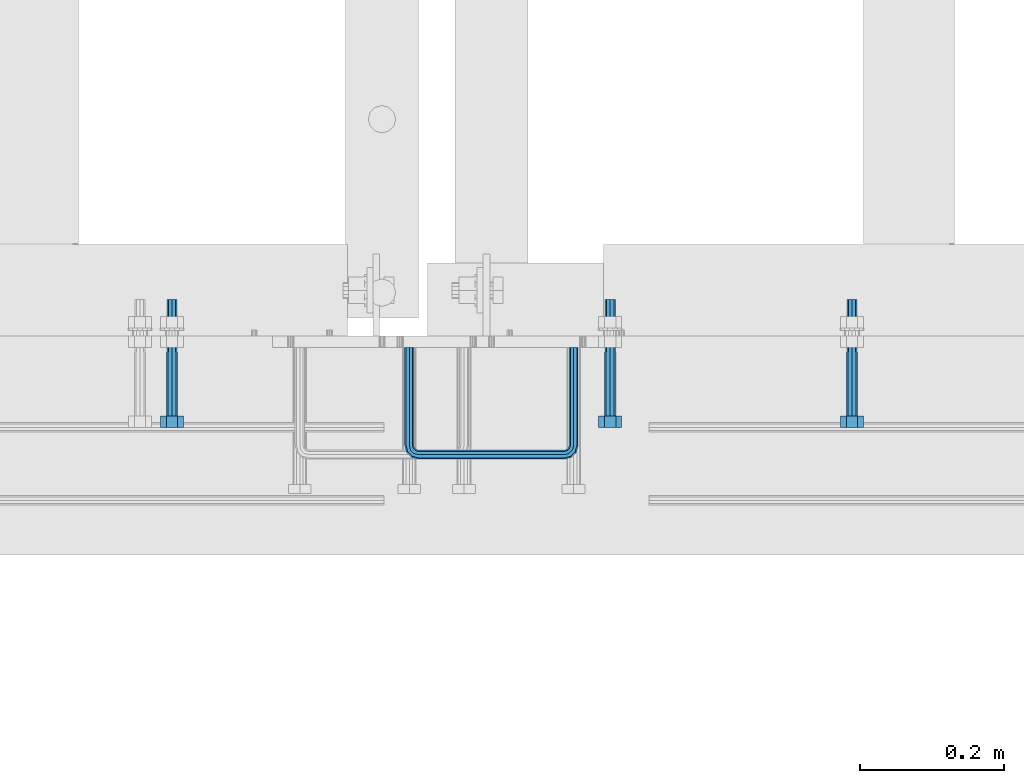
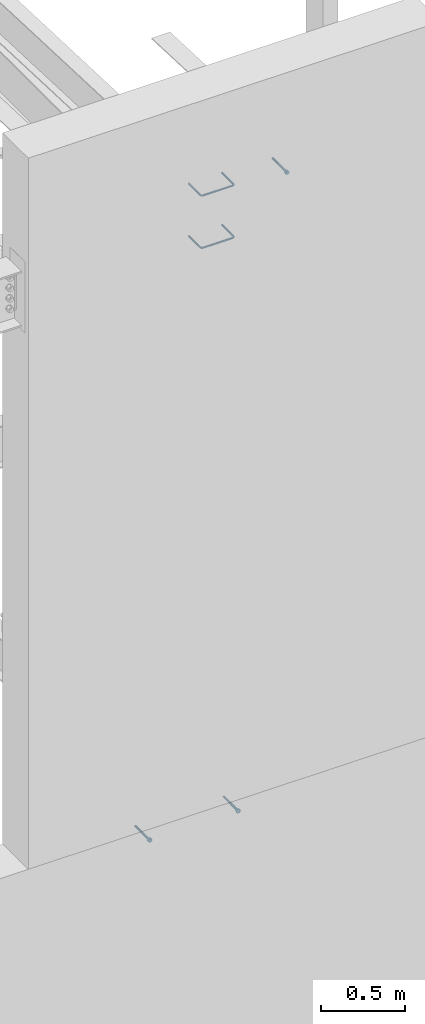
# One storey, part 408 of 975: 5 beams.
"""IFC2X3 building model written with IfcOpenShell, lengths in millimetres."""

import ifcopenshell
import ifcopenshell.guid

model = None  # the IFC model being written
_history = None  # IfcOwnerHistory: only IFC2X3 demands one
_inside = {}  # id of a spatial element -> (the spatial element, [elements in it])
_under = {}  # id of a project, library or spatial element -> (it, [spatial elements below it])
_declared = {}  # id of a project -> (the project, [libraries it declares])
_typed = {}  # id of a type object -> (the type object, [elements of that type])
_made_of = {}  # id of a material, layer set ... -> (it, [elements and type objects made of it])


def new_model(schema):
    """Start an empty IFC model of exactly this schema.

    Asked for "IFC4X3", IfcOpenShell would pick the latest addendum, in which some entities
    have other attributes; the version numbers below select the first issue.
    IFC2X3 requires an IfcOwnerHistory on every rooted entity: one is made here for all.
    """
    global model, _history
    if schema == "IFC4X3":
        model = ifcopenshell.file(schema_version=(4, 3, 0, 0))
    else:
        model = ifcopenshell.file(schema=schema)
    _inside.clear()
    _under.clear()
    _declared.clear()
    _typed.clear()
    _made_of.clear()
    _history = None
    if model.schema == "IFC2X3":
        org = make("IfcOrganization", Name="unknown")
        user = make(
            "IfcPersonAndOrganization",
            ThePerson=make("IfcPerson", FamilyName="unknown"),
            TheOrganization=org,
        )
        app = make(
            "IfcApplication",
            ApplicationDeveloper=org,
            Version="unknown",
            ApplicationFullName="unknown",
            ApplicationIdentifier="unknown",
        )
        _history = make(
            "IfcOwnerHistory",
            OwningUser=user,
            OwningApplication=app,
            ChangeAction="ADDED",
            CreationDate=0,
        )
    return model


def make(cls, **values):
    """One entity of the class cls with the attributes given. An attribute that is None is left unset."""
    return model.create_entity(
        cls, **{name: value for name, value in values.items() if value is not None}
    )


def rooted(cls, **values):
    """An entity with a GlobalId (a new one), such as an element, a storey or a relation."""
    return make(cls, GlobalId=ifcopenshell.guid.new(), OwnerHistory=_history, **values)


def si_unit(unit_type, name, prefix=None):
    """IfcSIUnit, for example si_unit("LENGTHUNIT", "METRE", prefix="MILLI")."""
    return make("IfcSIUnit", UnitType=unit_type, Prefix=prefix, Name=name)


def assignment(units):
    """IfcUnitAssignment: the units of a project."""
    return None if units is None else make("IfcUnitAssignment", Units=units)


def point(xyz):
    """IfcCartesianPoint."""
    return None if xyz is None else make("IfcCartesianPoint", Coordinates=xyz)


def direction(xyz):
    """IfcDirection."""
    return None if xyz is None else make("IfcDirection", DirectionRatios=xyz)


def frame(location, z_axis=None, x_axis=None):
    """IfcAxis2Placement3D, a coordinate frame: its origin and axes. An axis left out is left unset."""
    return make(
        "IfcAxis2Placement3D",
        Location=point(location),
        Axis=direction(z_axis),
        RefDirection=direction(x_axis),
    )


def origin_with_axes():
    """The frame at (0, 0, 0) with the z axis (0, 0, 1) and the x axis (1, 0, 0) written out."""
    return frame((0.0, 0.0, 0.0), z_axis=(0.0, 0.0, 1.0), x_axis=(1.0, 0.0, 0.0))


def place(relative_to, where):
    """IfcLocalPlacement: puts the frame where relative to a parent placement (None: the world)."""
    return make(
        "IfcLocalPlacement", PlacementRelTo=relative_to, RelativePlacement=where
    )


def context(
    kind, dimensions, precision=None, world=None, true_north=None, identifier=None
):
    """IfcGeometricRepresentationContext, for example the 3D "Model" context."""
    return make(
        "IfcGeometricRepresentationContext",
        ContextIdentifier=identifier,
        ContextType=kind,
        CoordinateSpaceDimension=dimensions,
        Precision=precision,
        WorldCoordinateSystem=world,
        TrueNorth=true_north,
    )


def subcontext(parent, identifier, kind, view, scale=None):
    """IfcGeometricRepresentationSubContext, for example "Body" below "Model"."""
    return make(
        "IfcGeometricRepresentationSubContext",
        ContextIdentifier=identifier,
        ContextType=kind,
        ParentContext=parent,
        TargetScale=scale,
        TargetView=view,
    )


def project(units=None, contexts=None):
    """IfcProject with its units and contexts."""
    return rooted(
        "IfcProject",
        Name="project",
        RepresentationContexts=contexts,
        UnitsInContext=assignment(units),
    )


def spatial(cls, under=None, at=None, **own):
    """A site, building, storey or space (cls), placed at a placement, below another one or the project."""
    s = rooted(cls, ObjectPlacement=at, **own)
    if under is not None:
        _under.setdefault(under.id(), (under, []))[1].append(s)
    return s


def faces_of(points, faces, orient=None, outer=None):
    """IfcFace entities. A face is a list of loops; a loop is a list of indices into points, from 0.

    orient and outer hold one flag for each loop. By default every Orientation is true, the
    first loop of a face is its IfcFaceOuterBound and the others are IfcFaceBound.
    """
    made = []
    for i, loops in enumerate(faces):
        bounds = []
        for j, loop in enumerate(loops):
            is_outer = j == 0 if outer is None else outer[i][j]
            bounds.append(
                make(
                    "IfcFaceOuterBound" if is_outer else "IfcFaceBound",
                    Bound=make("IfcPolyLoop", Polygon=[points[k] for k in loop]),
                    Orientation=True if orient is None else orient[i][j],
                )
            )
        made.append(make("IfcFace", Bounds=bounds))
    return made


def faceted_brep(points, faces, orient=None, outer=None, voids=None):
    """IfcFacetedBrep: a solid bounded by flat faces; with voids (closed shells), ...WithVoids."""
    shared = [point(p) for p in points]
    hull = make("IfcClosedShell", CfsFaces=faces_of(shared, faces, orient, outer))
    if voids is None:
        return make("IfcFacetedBrep", Outer=hull)
    return make(
        "IfcFacetedBrepWithVoids",
        Outer=hull,
        Voids=[
            make(cls, CfsFaces=faces_of(shared, fs, o, b)) for cls, fs, o, b in voids
        ],
    )


def shape(context_of_items, identifier, shape_type, items):
    """IfcShapeRepresentation: the items that make up one representation, for example the "Body"."""
    return make(
        "IfcShapeRepresentation",
        ContextOfItems=context_of_items,
        RepresentationIdentifier=identifier,
        RepresentationType=shape_type,
        Items=items,
    )


def material(Name=None, Category=None):
    """IfcMaterial."""
    return make("IfcMaterial", Name=Name, Category=Category)


def made_of(thing, what):
    """Note that an element or type object is made of a material, layer set ...; save() writes the relation."""
    if what is not None:
        _made_of.setdefault(what.id(), (what, []))[1].append(thing)
    return thing


def type_object(cls, material=None, **own):
    """A type object (cls), such as IfcWallType, which elements share."""
    return made_of(rooted(cls, **own), material)


def element(
    cls,
    number,
    at=None,
    inside=None,
    cuts=None,
    type_object=None,
    material=None,
    context=None,
    identifier="Body",
    shape_type=None,
    held_by="IfcProductDefinitionShape",
    body=None,
    shapes=None,
    **own,
):
    """One element of the class cls, such as IfcWall. Its Tag is "e" and its number.

    at: its placement. inside: the storey or other place that contains it. cuts: it is an
    opening in that element (IfcRelVoidsElement). A single representation is given by context,
    identifier, shape_type and body (its items); several are given by shapes. held_by: the class
    of the entity that holds the representations. save() writes the other relations.
    """
    e = rooted(cls, Tag="e%d" % number, ObjectPlacement=at, **own)
    if body is not None:
        shapes = [shape(context, identifier, shape_type, body)]
    if shapes is not None:
        e.Representation = make(held_by, Representations=shapes)
    if inside is not None:
        _inside.setdefault(inside.id(), (inside, []))[1].append(e)
    if cuts is not None:
        rooted(
            "IfcRelVoidsElement", RelatingBuildingElement=cuts, RelatedOpeningElement=e
        )
    if type_object is not None:
        _typed.setdefault(type_object.id(), (type_object, []))[1].append(e)
    return made_of(e, material)


def aggregate(whole, parts):
    """IfcRelAggregates: a whole, such as a stair, and the parts it consists of."""
    return rooted("IfcRelAggregates", RelatingObject=whole, RelatedObjects=parts)


def save(model, path):
    """Write the relations noted so far, then the file.

    IfcRelAggregates (storeys below a building ...), IfcRelContainedInSpatialStructure (elements
    in a storey), IfcRelDefinesByType, IfcRelAssociatesMaterial and IfcRelDeclares: one each for
    every whole, place, type object, material and project.
    """
    for whole, parts in _under.values():
        aggregate(whole, parts)
    for where, things in _inside.values():
        rooted(
            "IfcRelContainedInSpatialStructure",
            RelatedElements=things,
            RelatingStructure=where,
        )
    for kind, things in _typed.values():
        rooted("IfcRelDefinesByType", RelatedObjects=things, RelatingType=kind)
    for what, things in _made_of.values():
        rooted("IfcRelAssociatesMaterial", RelatedObjects=things, RelatingMaterial=what)
    for by, libraries in _declared.values():
        rooted("IfcRelDeclares", RelatingContext=by, RelatedDefinitions=libraries)
    model.write(path)


model = new_model("IFC2X3")

# Units and contexts
model_context = context("Model", 3, precision=1e-05, world=origin_with_axes())
body_context = subcontext(model_context, "Body", "Model", "MODEL_VIEW")
ifc_project = project(units=[si_unit("LENGTHUNIT", "METRE", prefix="MILLI"), si_unit("AREAUNIT", "SQUARE_METRE"), si_unit("VOLUMEUNIT", "CUBIC_METRE"), si_unit("MASSUNIT", "GRAM", prefix="KILO"), si_unit("TIMEUNIT", "SECOND"), si_unit("PLANEANGLEUNIT", "RADIAN"), si_unit("SOLIDANGLEUNIT", "STERADIAN"), si_unit("THERMODYNAMICTEMPERATUREUNIT", "DEGREE_CELSIUS"), si_unit("LUMINOUSINTENSITYUNIT", "LUMEN")], contexts=[model_context])

# Site, building, storey
site_placement = place(None, origin_with_axes())
site = spatial("IfcSite", under=ifc_project, at=site_placement, CompositionType="ELEMENT")
building_placement = place(site_placement, origin_with_axes())
building = spatial("IfcBuilding", under=site, at=building_placement, Name="Undefined", CompositionType="ELEMENT")
storey_placement = place(building_placement, origin_with_axes())
storey = spatial("IfcBuildingStorey", under=building, at=storey_placement, Name="Undefined", CompositionType="ELEMENT", Elevation=0.0)

# Beams
ifc_material_1 = material(Name="STEEL/F1554-36")
beam_type_1 = type_object("IfcBeamType", PredefinedType="NOTDEFINED")
beam_1_placement = place(storey_placement, frame((24225.2500236716, 282.575084098113, 8420.10000031656), z_axis=(0.0, 0.0, -1.0), x_axis=(0.0, -1.0, 0.0)))
element("IfcBeam", 1, at=beam_1_placement, inside=storey, type_object=beam_type_1, material=ifc_material_1, Name="HEADED_ANCHOR_BOLT", context=body_context, shape_type="Brep", body=[
    faceted_brep([(88.9000000184824, 7.94000001861696, -13.7499999799138), (88.8999999527368, 15.8800000758411, 2.00943759409711e-08), (104.774999952569, 15.8800001213949, 6.97191353538074e-08), (104.775000018315, 7.94000006417082, -13.7499999302891), (88.900000064019, -7.94000009583215, -13.7499999799147), (104.775000063852, -7.9400000502792, -13.74999993029), (88.9000000438027, -15.880000153059, 2.00925569515675e-08), (104.775000043643, -15.8800001075042, 6.9716406869702e-08), (88.8999999780608, -7.94000009583488, 13.7500000200998), (104.774999977893, -7.94000005028101, 13.7500000697237), (88.8999999325279, 7.94000001861514, 13.7500000201007), (104.774999932361, 7.940000064169, 13.7500000697246), (88.9000000119959, 3.78780480527439, -7.86545778426807), (88.8999999957159, 6.82538844544797, -5.4430656647246), (88.8999999799416, 8.51112018845743, -1.94260763148395), (88.8999999677944, 8.51112018845652, 1.94260767167179), (88.8999999616899, 6.82538844544615, 5.44306570491244), (88.8999999628249, 3.78780480527257, 7.86545782445592), (88.8999999709849, -3.86089595849626e-08, 8.72999956233434), (88.8999999845473, -3.7878048824914, 7.8654578244541), (88.9000000008309, -6.82538852266407, 5.44306570491153), (88.9000000166052, -8.51112026567444, 1.94260767166998), (88.9000000287488, -8.51112026567353, -1.94260763148577), (88.9000000348606, -6.82538852266407, -5.44306566472642), (88.9000000337182, -3.78780488248958, -7.86545778426898), (88.9000000255583, -3.86080500902608e-08, -8.72999952214832), (104.775000025395, 6.94581103743985e-09, -8.72999947252447), (104.775000011829, 3.78780485082825, -7.86545773464422), (104.774999995549, 6.82538849100092, -5.44306561510075), (104.774999979774, 8.51112023401038, -1.9426075818601), (104.774999967627, 8.51112023401038, 1.94260772129564), (104.774999961523, 6.82538849100092, 5.44306575453629), (104.774999962658, 3.78780485082643, 7.86545787407977), (104.774999970818, 6.94399204803631e-09, 8.7299996119591), (104.77499998438, -3.78780483693754, 7.86545787407886), (104.775000000664, -6.82538847711112, 5.44306575453538), (104.775000016438, -8.51112022012057, 1.94260772129473), (104.775000028581, -8.51112022012057, -1.94260758186101), (104.775000034693, -6.82538847711021, -5.44306561510166), (104.775000033551, -3.78780483693663, -7.86545773464422), (-2.99107341561466e-07, -5.61266007567065, 5.61266007566792), (-4.22995071858168e-07, -7.93750000000728, 0.0), (104.774999998088, -7.93749999999, -4.45652403868735e-11), (104.774999998088, -5.61266007565791, 5.61266007562426), (-1.09139364212751e-11, 1.81898940354586e-12, 7.9375), (104.774999998095, 1.18234311230481e-11, 7.93749999995816), (2.99089151667431e-07, 5.61266007567428, 5.61266007566792), (104.774999998102, 5.61266007568065, 5.61266007562517), (4.22980519942939e-07, 7.93750000001091, 0.0), (104.77499999811, 7.93750000001364, -4.36557456851006e-11), (2.99089151667431e-07, 5.61266007567428, -5.61266007566792), (104.774999998102, 5.61266007568156, -5.61266007571339), (-1.09139364212751e-11, 1.81898940354586e-12, -7.9375), (104.774999998099, 1.2732925824821e-11, -7.93750000004547), (-73.0249999592124, 5.05157065939329, -5.0515715445581), (-73.0249999269472, -1.85405951924622e-07, -7.14400069976364), (-73.0249999328516, -5.0515710302052, -5.05157154455992), (-73.0249999734697, -7.14400018541073, -6.9975976657588e-07), (-73.0250000250016, -5.05157103020611, 5.05157014504039), (-73.0250000572705, -1.85406861419324e-07, 7.1439993002441), (-73.0250000513661, 5.05157065939238, 5.05157014503948), (-73.025000010748, 7.14399981459792, -6.99758857081179e-07), (0.00625003290042514, 5.05157085007795, -5.05157087849238), (0.00625006516929716, 5.27870724909008e-09, -7.1440000336961), (0.00625005926485755, -5.05157083952145, -5.05157087849329), (0.00625001864682417, -7.14399999472516, -3.36940502165817e-08), (0.00624996711121639, -5.05157083952145, 5.05157081110519), (0.00624993484598235, 5.2777977543883e-09, 7.14399996631164), (0.00624994074678398, 5.05157085007704, 5.05157081110701), (0.00624998136845534, 7.14400000528167, -3.36922312271781e-08), (-2.99107341561466e-07, -5.61266007567065, -5.61266007566792), (104.774999998092, -5.612660075657, -5.6126600757143)], [[[0, 1, 2, 3]], [[4, 0, 3, 5]], [[6, 4, 5, 7]], [[8, 6, 7, 9]], [[10, 8, 9, 11]], [[0, 4, 6, 8, 10, 1], [12, 13, 14, 15, 16, 17, 18, 19, 20, 21, 22, 23, 24, 25]], [[12, 25, 26, 27]], [[13, 12, 27, 28]], [[14, 13, 28, 29]], [[15, 14, 29, 30]], [[16, 15, 30, 31]], [[17, 16, 31, 32]], [[18, 17, 32, 33]], [[19, 18, 33, 34]], [[20, 19, 34, 35]], [[21, 20, 35, 36]], [[22, 21, 36, 37]], [[23, 22, 37, 38]], [[24, 23, 38, 39]], [[25, 24, 39, 26]], [[9, 7, 5, 3, 2, 11], [38, 37, 36, 35, 34, 33, 32, 31, 30, 29, 28, 27, 26, 39]], [[1, 10, 11, 2]], [[40, 41, 42, 43]], [[44, 40, 43, 45]], [[46, 44, 45, 47]], [[48, 46, 47, 49]], [[50, 48, 49, 51]], [[52, 50, 51, 53]], [[54, 55, 56, 57, 58, 59, 60, 61]], [[55, 54, 62, 63]], [[56, 55, 63, 64]], [[57, 56, 64, 65]], [[58, 57, 65, 66]], [[59, 58, 66, 67]], [[60, 59, 67, 68]], [[61, 60, 68, 69]], [[54, 61, 69, 62]], [[40, 44, 46, 48, 50, 52, 70, 41], [68, 67, 66, 65, 64, 63, 62, 69]], [[41, 70, 71, 42]], [[53, 51, 49, 47, 45, 43, 42, 71]], [[70, 52, 53, 71]]]),
])
beam_2_placement = place(storey_placement, frame((23279.1, 282.575000000001, 3886.2), z_axis=(0.0, 0.0, 1.0), x_axis=(0.0, -1.0, 0.0)))
element("IfcBeam", 2, at=beam_2_placement, inside=storey, type_object=beam_type_1, material=ifc_material_1, Name="HEADED_ANCHOR_BOLT", context=body_context, shape_type="Brep", body=[
    faceted_brep([(88.9000000184824, 7.94000001861696, -13.7499999799138), (88.8999999527368, 15.8800000758411, 2.00943759409711e-08), (104.774999952569, 15.8800001213949, 6.97191353538074e-08), (104.775000018315, 7.94000006417082, -13.7499999302891), (88.900000064019, -7.94000009583215, -13.7499999799147), (104.775000063852, -7.9400000502792, -13.74999993029), (88.9000000438027, -15.880000153059, 2.00925569515675e-08), (104.775000043643, -15.8800001075042, 6.9716406869702e-08), (88.8999999780608, -7.94000009583488, 13.7500000200998), (104.774999977893, -7.94000005028101, 13.7500000697237), (88.8999999325279, 7.94000001861514, 13.7500000201007), (104.774999932361, 7.940000064169, 13.7500000697246), (88.9000000119959, 3.78780480527439, -7.86545778426807), (88.8999999957159, 6.82538844544797, -5.4430656647246), (88.8999999799416, 8.51112018845743, -1.94260763148395), (88.8999999677944, 8.51112018845652, 1.94260767167179), (88.8999999616899, 6.82538844544615, 5.44306570491244), (88.8999999628249, 3.78780480527257, 7.86545782445592), (88.8999999709849, -3.86089595849626e-08, 8.72999956233434), (88.8999999845473, -3.7878048824914, 7.8654578244541), (88.9000000008309, -6.82538852266407, 5.44306570491153), (88.9000000166052, -8.51112026567444, 1.94260767166998), (88.9000000287488, -8.51112026567353, -1.94260763148577), (88.9000000348606, -6.82538852266407, -5.44306566472642), (88.9000000337182, -3.78780488248958, -7.86545778426898), (88.9000000255583, -3.86080500902608e-08, -8.72999952214832), (104.775000025395, 6.94581103743985e-09, -8.72999947252447), (104.775000011829, 3.78780485082825, -7.86545773464422), (104.774999995549, 6.82538849100092, -5.44306561510075), (104.774999979774, 8.51112023401038, -1.9426075818601), (104.774999967627, 8.51112023401038, 1.94260772129564), (104.774999961523, 6.82538849100092, 5.44306575453629), (104.774999962658, 3.78780485082643, 7.86545787407977), (104.774999970818, 6.94399204803631e-09, 8.7299996119591), (104.77499998438, -3.78780483693754, 7.86545787407886), (104.775000000664, -6.82538847711112, 5.44306575453538), (104.775000016438, -8.51112022012057, 1.94260772129473), (104.775000028581, -8.51112022012057, -1.94260758186101), (104.775000034693, -6.82538847711021, -5.44306561510166), (104.775000033551, -3.78780483693663, -7.86545773464422), (-2.99107341561466e-07, -5.61266007567065, 5.61266007566792), (-4.22995071858168e-07, -7.93750000000728, 0.0), (104.774999998088, -7.93749999999, -4.45652403868735e-11), (104.774999998088, -5.61266007565791, 5.61266007562426), (-1.09139364212751e-11, 1.81898940354586e-12, 7.9375), (104.774999998095, 1.18234311230481e-11, 7.93749999995816), (2.99089151667431e-07, 5.61266007567428, 5.61266007566792), (104.774999998102, 5.61266007568065, 5.61266007562517), (4.22980519942939e-07, 7.93750000001091, 0.0), (104.77499999811, 7.93750000001364, -4.36557456851006e-11), (2.99089151667431e-07, 5.61266007567428, -5.61266007566792), (104.774999998102, 5.61266007568156, -5.61266007571339), (-1.09139364212751e-11, 1.81898940354586e-12, -7.9375), (104.774999998099, 1.2732925824821e-11, -7.93750000004547), (-73.0249999592124, 5.05157065939329, -5.0515715445581), (-73.0249999269472, -1.85405951924622e-07, -7.14400069976364), (-73.0249999328516, -5.0515710302052, -5.05157154455992), (-73.0249999734697, -7.14400018541073, -6.9975976657588e-07), (-73.0250000250016, -5.05157103020611, 5.05157014504039), (-73.0250000572705, -1.85406861419324e-07, 7.1439993002441), (-73.0250000513661, 5.05157065939238, 5.05157014503948), (-73.025000010748, 7.14399981459792, -6.99758857081179e-07), (0.00625003290042514, 5.05157085007795, -5.05157087849238), (0.00625006516929716, 5.27870724909008e-09, -7.1440000336961), (0.00625005926485755, -5.05157083952145, -5.05157087849329), (0.00625001864682417, -7.14399999472516, -3.36940502165817e-08), (0.00624996711121639, -5.05157083952145, 5.05157081110519), (0.00624993484598235, 5.2777977543883e-09, 7.14399996631164), (0.00624994074678398, 5.05157085007704, 5.05157081110701), (0.00624998136845534, 7.14400000528167, -3.36922312271781e-08), (-2.99107341561466e-07, -5.61266007567065, -5.61266007566792), (104.774999998092, -5.612660075657, -5.6126600757143)], [[[0, 1, 2, 3]], [[4, 0, 3, 5]], [[6, 4, 5, 7]], [[8, 6, 7, 9]], [[10, 8, 9, 11]], [[0, 4, 6, 8, 10, 1], [12, 13, 14, 15, 16, 17, 18, 19, 20, 21, 22, 23, 24, 25]], [[12, 25, 26, 27]], [[13, 12, 27, 28]], [[14, 13, 28, 29]], [[15, 14, 29, 30]], [[16, 15, 30, 31]], [[17, 16, 31, 32]], [[18, 17, 32, 33]], [[19, 18, 33, 34]], [[20, 19, 34, 35]], [[21, 20, 35, 36]], [[22, 21, 36, 37]], [[23, 22, 37, 38]], [[24, 23, 38, 39]], [[25, 24, 39, 26]], [[9, 7, 5, 3, 2, 11], [38, 37, 36, 35, 34, 33, 32, 31, 30, 29, 28, 27, 26, 39]], [[1, 10, 11, 2]], [[40, 41, 42, 43]], [[44, 40, 43, 45]], [[46, 44, 45, 47]], [[48, 46, 47, 49]], [[50, 48, 49, 51]], [[52, 50, 51, 53]], [[54, 55, 56, 57, 58, 59, 60, 61]], [[55, 54, 62, 63]], [[56, 55, 63, 64]], [[57, 56, 64, 65]], [[58, 57, 65, 66]], [[59, 58, 66, 67]], [[60, 59, 67, 68]], [[61, 60, 68, 69]], [[54, 61, 69, 62]], [[40, 44, 46, 48, 50, 52, 70, 41], [68, 67, 66, 65, 64, 63, 62, 69]], [[41, 70, 71, 42]], [[53, 51, 49, 47, 45, 43, 42, 71]], [[70, 52, 53, 71]]]),
])
beam_3_placement = place(storey_placement, frame((23888.7, 282.575000000001, 3886.2), z_axis=(0.0, 0.0, -1.0), x_axis=(0.0, -1.0, 0.0)))
element("IfcBeam", 3, at=beam_3_placement, inside=storey, type_object=beam_type_1, material=ifc_material_1, Name="HEADED_ANCHOR_BOLT", context=body_context, shape_type="Brep", body=[
    faceted_brep([(88.9000000184824, 7.94000001861696, -13.7499999799138), (88.8999999527368, 15.8800000758411, 2.00943759409711e-08), (104.774999952569, 15.8800001213949, 6.97191353538074e-08), (104.775000018315, 7.94000006417082, -13.7499999302891), (88.900000064019, -7.94000009583215, -13.7499999799147), (104.775000063852, -7.9400000502792, -13.74999993029), (88.9000000438027, -15.880000153059, 2.00925569515675e-08), (104.775000043643, -15.8800001075042, 6.9716406869702e-08), (88.8999999780608, -7.94000009583488, 13.7500000200998), (104.774999977893, -7.94000005028101, 13.7500000697237), (88.8999999325279, 7.94000001861514, 13.7500000201007), (104.774999932361, 7.940000064169, 13.7500000697246), (88.9000000119959, 3.78780480527439, -7.86545778426807), (88.8999999957159, 6.82538844544797, -5.4430656647246), (88.8999999799416, 8.51112018845743, -1.94260763148395), (88.8999999677944, 8.51112018845652, 1.94260767167179), (88.8999999616899, 6.82538844544615, 5.44306570491244), (88.8999999628249, 3.78780480527257, 7.86545782445592), (88.8999999709849, -3.86089595849626e-08, 8.72999956233434), (88.8999999845473, -3.7878048824914, 7.8654578244541), (88.9000000008309, -6.82538852266407, 5.44306570491153), (88.9000000166052, -8.51112026567444, 1.94260767166998), (88.9000000287488, -8.51112026567353, -1.94260763148577), (88.9000000348606, -6.82538852266407, -5.44306566472642), (88.9000000337182, -3.78780488248958, -7.86545778426898), (88.9000000255583, -3.86080500902608e-08, -8.72999952214832), (104.775000025395, 6.94581103743985e-09, -8.72999947252447), (104.775000011829, 3.78780485082825, -7.86545773464422), (104.774999995549, 6.82538849100092, -5.44306561510075), (104.774999979774, 8.51112023401038, -1.9426075818601), (104.774999967627, 8.51112023401038, 1.94260772129564), (104.774999961523, 6.82538849100092, 5.44306575453629), (104.774999962658, 3.78780485082643, 7.86545787407977), (104.774999970818, 6.94399204803631e-09, 8.7299996119591), (104.77499998438, -3.78780483693754, 7.86545787407886), (104.775000000664, -6.82538847711112, 5.44306575453538), (104.775000016438, -8.51112022012057, 1.94260772129473), (104.775000028581, -8.51112022012057, -1.94260758186101), (104.775000034693, -6.82538847711021, -5.44306561510166), (104.775000033551, -3.78780483693663, -7.86545773464422), (-2.99107341561466e-07, -5.61266007567065, 5.61266007566792), (-4.22995071858168e-07, -7.93750000000728, 0.0), (104.774999998088, -7.93749999999, -4.45652403868735e-11), (104.774999998088, -5.61266007565791, 5.61266007562426), (-1.09139364212751e-11, 1.81898940354586e-12, 7.9375), (104.774999998095, 1.18234311230481e-11, 7.93749999995816), (2.99089151667431e-07, 5.61266007567428, 5.61266007566792), (104.774999998102, 5.61266007568065, 5.61266007562517), (4.22980519942939e-07, 7.93750000001091, 0.0), (104.77499999811, 7.93750000001364, -4.36557456851006e-11), (2.99089151667431e-07, 5.61266007567428, -5.61266007566792), (104.774999998102, 5.61266007568156, -5.61266007571339), (-1.09139364212751e-11, 1.81898940354586e-12, -7.9375), (104.774999998099, 1.2732925824821e-11, -7.93750000004547), (-73.0249999592124, 5.05157065939329, -5.0515715445581), (-73.0249999269472, -1.85405951924622e-07, -7.14400069976364), (-73.0249999328516, -5.0515710302052, -5.05157154455992), (-73.0249999734697, -7.14400018541073, -6.9975976657588e-07), (-73.0250000250016, -5.05157103020611, 5.05157014504039), (-73.0250000572705, -1.85406861419324e-07, 7.1439993002441), (-73.0250000513661, 5.05157065939238, 5.05157014503948), (-73.025000010748, 7.14399981459792, -6.99758857081179e-07), (0.00625003290042514, 5.05157085007795, -5.05157087849238), (0.00625006516929716, 5.27870724909008e-09, -7.1440000336961), (0.00625005926485755, -5.05157083952145, -5.05157087849329), (0.00625001864682417, -7.14399999472516, -3.36940502165817e-08), (0.00624996711121639, -5.05157083952145, 5.05157081110519), (0.00624993484598235, 5.2777977543883e-09, 7.14399996631164), (0.00624994074678398, 5.05157085007704, 5.05157081110701), (0.00624998136845534, 7.14400000528167, -3.36922312271781e-08), (-2.99107341561466e-07, -5.61266007567065, -5.61266007566792), (104.774999998092, -5.612660075657, -5.6126600757143)], [[[0, 1, 2, 3]], [[4, 0, 3, 5]], [[6, 4, 5, 7]], [[8, 6, 7, 9]], [[10, 8, 9, 11]], [[0, 4, 6, 8, 10, 1], [12, 13, 14, 15, 16, 17, 18, 19, 20, 21, 22, 23, 24, 25]], [[12, 25, 26, 27]], [[13, 12, 27, 28]], [[14, 13, 28, 29]], [[15, 14, 29, 30]], [[16, 15, 30, 31]], [[17, 16, 31, 32]], [[18, 17, 32, 33]], [[19, 18, 33, 34]], [[20, 19, 34, 35]], [[21, 20, 35, 36]], [[22, 21, 36, 37]], [[23, 22, 37, 38]], [[24, 23, 38, 39]], [[25, 24, 39, 26]], [[9, 7, 5, 3, 2, 11], [38, 37, 36, 35, 34, 33, 32, 31, 30, 29, 28, 27, 26, 39]], [[1, 10, 11, 2]], [[40, 41, 42, 43]], [[44, 40, 43, 45]], [[46, 44, 45, 47]], [[48, 46, 47, 49]], [[50, 48, 49, 51]], [[52, 50, 51, 53]], [[54, 55, 56, 57, 58, 59, 60, 61]], [[55, 54, 62, 63]], [[56, 55, 63, 64]], [[57, 56, 64, 65]], [[58, 57, 65, 66]], [[59, 58, 66, 67]], [[60, 59, 67, 68]], [[61, 60, 68, 69]], [[54, 61, 69, 62]], [[40, 44, 46, 48, 50, 52, 70, 41], [68, 67, 66, 65, 64, 63, 62, 69]], [[41, 70, 71, 42]], [[53, 51, 49, 47, 45, 43, 42, 71]], [[70, 52, 53, 71]]]),
])
ifc_material_2 = material(Name="STEEL/A706")
beam_type_2 = type_object("IfcBeamType", Name="#4 TIE", PredefinedType="NOTDEFINED")
beam_4_placement = place(storey_placement, frame((23837.899991351, 288.925010501542, 8109.74772216187), z_axis=(-0.999999999999998, 6.90000001668524e-08, 0.0), x_axis=(0.0, -1.0, 0.0)))
element("IfcBeam", 4, at=beam_4_placement, inside=storey, type_object=beam_type_2, material=ifc_material_2, Name="TIE ROD", ObjectType="#4 TIE", context=body_context, shape_type="Brep", body=[
    faceted_brep([(0.0, -6.34999999998763, -3.63797880709171e-12), (0.0, -4.49012806052269, -4.49012806054634), (136.525006144455, -4.49012806053452, -4.49012811661669), (136.525006146271, -6.35000000000036, -5.60821717954241e-08), (0.0, 7.27595761418343e-12, -6.35000000000764), (136.525006143703, 0.0, -6.35000005608254), (0.0, 4.49012806053724, -4.49012806053906), (136.525006144455, 4.49012806053452, -4.49012811661669), (0.0, 6.34999999999491, 5.45696821063757e-12), (136.525006146271, 6.35000000000036, -5.60821717954241e-08), (0.0, 4.49012806052633, 4.49012806054634), (136.525006148087, 4.49012806053452, 4.49012800445234), (0.0, 0.0, 6.35000000000764), (136.525006148839, 0.0, 6.34999994391819), (0.0, -4.49012806053361, 4.49012806053543), (136.525006148087, -4.49012806053452, 4.49012800445234), (146.050006113442, 0.0, -3.79778399058796), (145.120070138105, -4.49012806053452, -2.1870876464609), (142.875006094308, -6.35000000000036, 1.70147731239558), (140.62994205051, -4.49012806053452, 5.59004227125297), (139.700006075173, 0.0, 7.20073861538003), (140.62994205051, 4.49012806053452, 5.59004227125297), (142.875006094308, 6.35000000000036, 1.70147731239558), (145.120070138105, 4.49012806053452, -2.1870876464609), (151.412093644245, 4.49012806053452, 4.10493592790226), (153.022789998455, 0.0, 3.1749999700296), (147.523528661045, 6.35000000000036, 6.34999992953635), (143.634963677846, 4.49012806053452, 8.59506393117135), (142.024267323636, 0.0, 9.5249998890431), (143.634963677846, -4.49012806053452, 8.59506393117135), (147.523528661045, -6.35000000000036, 6.34999992953635), (151.412093644245, -4.49012806053452, 4.10493592790226), (153.715134021207, 4.49012806053452, 12.6999999465306), (155.575005960673, 0.0, 12.6999999674508), (149.225005960672, 6.35000000000036, 12.6999998960273), (144.734877900137, 4.49012806053452, 12.699999845524), (142.875005960672, 0.0, 12.6999998246056), (144.734877900137, -4.49012806053452, 12.699999845524), (149.225005960671, -6.35000000000036, 12.6999998960273), (153.715134021207, -4.49012806053452, 12.6999999465306), (153.71513173569, -4.49012806053452, 215.900003176369), (149.225003675155, -6.35000000000036, 215.900003125867), (155.575003675155, 0.0, 215.900003197289), (153.71513173569, 4.49012806053452, 215.900003176369), (149.225003675155, 6.35000000000036, 215.900003125867), (144.734875614621, 4.49012806053452, 215.900003075363), (142.875003675155, 0.0, 215.900003054444), (144.734875614621, -4.49012806053452, 215.900003075363), (153.022787648382, 0.0, 225.425002877988), (151.412091300475, -4.49012806053452, 224.495066909199), (147.523526332491, -6.35000000000036, 222.25000288121), (143.634961364508, -4.49012806053452, 220.004938853222), (142.024265016601, 0.0, 219.075002884432), (143.634961364508, 4.49012806053452, 220.004938853222), (147.523526332491, 6.35000000000036, 222.25000288121), (151.412091300475, 4.49012806053452, 224.495066909199), (145.120067985683, 4.49012806053452, 230.787090305822), (146.05000397542, 0.0, 232.397786641635), (142.875003907121, 6.35000000000036, 226.898525367037), (140.629939828559, 4.49012806053452, 223.00996042825), (139.700003838822, 0.0, 221.399264092438), (140.629939828559, -4.49012806053452, 223.00996042825), (142.875003907121, -6.35000000000036, 226.898525367037), (145.120067985683, -4.49012806053452, 230.787090305822), (136.525004282814, 4.49012806053452, 233.090130852819), (136.525004327922, 0.0, 234.950002792285), (136.525004173912, 6.35000000000036, 228.600002792285), (136.52500406501, 4.49012806053452, 224.10987473175), (136.525004019901, 0.0, 222.250002792285), (136.52500406501, -4.49012806053452, 224.10987473175), (136.525004173912, -6.35000000000036, 228.600002792286), (136.525004282814, -4.49012806053452, 233.090130852819), (3.32236731992452e-06, -4.49012806053452, 233.090134164055), (3.21346533382894e-06, -6.35000000000036, 228.60000610352), (3.36747552864836e-06, 0.0, 234.95000610352), (3.32236731992452e-06, 4.49012806053452, 233.090134164055), (3.21346533382894e-06, 6.35000000000036, 228.60000610352), (3.104562892986e-06, 4.49012806053452, 224.109878042986), (3.05945422951481e-06, 0.0, 222.25000610352), (3.104562892986e-06, -4.49012806053452, 224.109878042986)], [[[0, 1, 2, 3]], [[1, 4, 5, 2]], [[4, 6, 7, 5]], [[6, 8, 9, 7]], [[8, 10, 11, 9]], [[10, 12, 13, 11]], [[12, 14, 15, 13]], [[14, 0, 3, 15]], [[14, 12, 10, 8, 6, 4, 1, 0]], [[2, 5, 16, 17]], [[3, 2, 17, 18]], [[15, 3, 18, 19]], [[13, 15, 19, 20]], [[11, 13, 20, 21]], [[9, 11, 21, 22]], [[7, 9, 22, 23]], [[5, 7, 23, 16]], [[23, 24, 25, 16]], [[22, 26, 24, 23]], [[21, 27, 26, 22]], [[20, 28, 27, 21]], [[19, 29, 28, 20]], [[18, 30, 29, 19]], [[17, 31, 30, 18]], [[16, 25, 31, 17]], [[24, 32, 33, 25]], [[26, 34, 32, 24]], [[27, 35, 34, 26]], [[28, 36, 35, 27]], [[29, 37, 36, 28]], [[30, 38, 37, 29]], [[31, 39, 38, 30]], [[25, 33, 39, 31]], [[38, 39, 40, 41]], [[39, 33, 42, 40]], [[33, 32, 43, 42]], [[32, 34, 44, 43]], [[34, 35, 45, 44]], [[35, 36, 46, 45]], [[36, 37, 47, 46]], [[37, 38, 41, 47]], [[40, 42, 48, 49]], [[41, 40, 49, 50]], [[47, 41, 50, 51]], [[46, 47, 51, 52]], [[45, 46, 52, 53]], [[44, 45, 53, 54]], [[43, 44, 54, 55]], [[42, 43, 55, 48]], [[55, 56, 57, 48]], [[54, 58, 56, 55]], [[53, 59, 58, 54]], [[52, 60, 59, 53]], [[51, 61, 60, 52]], [[50, 62, 61, 51]], [[49, 63, 62, 50]], [[48, 57, 63, 49]], [[56, 64, 65, 57]], [[58, 66, 64, 56]], [[59, 67, 66, 58]], [[60, 68, 67, 59]], [[61, 69, 68, 60]], [[62, 70, 69, 61]], [[63, 71, 70, 62]], [[57, 65, 71, 63]], [[70, 71, 72, 73]], [[71, 65, 74, 72]], [[65, 64, 75, 74]], [[64, 66, 76, 75]], [[66, 67, 77, 76]], [[67, 68, 78, 77]], [[68, 69, 79, 78]], [[69, 70, 73, 79]], [[74, 75, 76, 77, 78, 79, 73, 72]]]),
])
beam_5_placement = place(storey_placement, frame((23837.899991351, 288.925010501542, 8490.7477343689), z_axis=(-0.999999999999998, 6.90000001668524e-08, 0.0), x_axis=(0.0, -1.0, 0.0)))
element("IfcBeam", 5, at=beam_5_placement, inside=storey, type_object=beam_type_2, material=ifc_material_2, Name="TIE ROD", ObjectType="#4 TIE", context=body_context, shape_type="Brep", body=[
    faceted_brep([(0.0, -6.34999999998763, -3.63797880709171e-12), (0.0, -4.49012806052269, -4.49012806054634), (136.525006144455, -4.49012806053452, -4.49012811661669), (136.525006146271, -6.35000000000036, -5.60821717954241e-08), (0.0, 7.27595761418343e-12, -6.35000000000764), (136.525006143703, 0.0, -6.35000005608254), (0.0, 4.49012806053724, -4.49012806053906), (136.525006144455, 4.49012806053452, -4.49012811661669), (0.0, 6.34999999999491, 5.45696821063757e-12), (136.525006146271, 6.35000000000036, -5.60821717954241e-08), (0.0, 4.49012806052633, 4.49012806054634), (136.525006148087, 4.49012806053452, 4.49012800445234), (0.0, 0.0, 6.35000000000764), (136.525006148839, 0.0, 6.34999994391819), (0.0, -4.49012806053361, 4.49012806053543), (136.525006148087, -4.49012806053452, 4.49012800445234), (146.050006113442, 0.0, -3.79778399058796), (145.120070138105, -4.49012806053452, -2.1870876464609), (142.875006094308, -6.35000000000036, 1.70147731239558), (140.62994205051, -4.49012806053452, 5.59004227125297), (139.700006075173, 0.0, 7.20073861538003), (140.62994205051, 4.49012806053452, 5.59004227125297), (142.875006094308, 6.35000000000036, 1.70147731239558), (145.120070138105, 4.49012806053452, -2.1870876464609), (151.412093644245, 4.49012806053452, 4.10493592790226), (153.022789998455, 0.0, 3.1749999700296), (147.523528661045, 6.35000000000036, 6.34999992953635), (143.634963677846, 4.49012806053452, 8.59506393117135), (142.024267323636, 0.0, 9.5249998890431), (143.634963677846, -4.49012806053452, 8.59506393117135), (147.523528661045, -6.35000000000036, 6.34999992953635), (151.412093644245, -4.49012806053452, 4.10493592790226), (153.715134021207, 4.49012806053452, 12.6999999465306), (155.575005960673, 0.0, 12.6999999674508), (149.225005960672, 6.35000000000036, 12.6999998960273), (144.734877900137, 4.49012806053452, 12.699999845524), (142.875005960672, 0.0, 12.6999998246056), (144.734877900137, -4.49012806053452, 12.699999845524), (149.225005960671, -6.35000000000036, 12.6999998960273), (153.715134021207, -4.49012806053452, 12.6999999465306), (153.71513173569, -4.49012806053452, 215.900003176369), (149.225003675155, -6.35000000000036, 215.900003125867), (155.575003675155, 0.0, 215.900003197289), (153.71513173569, 4.49012806053452, 215.900003176369), (149.225003675155, 6.35000000000036, 215.900003125867), (144.734875614621, 4.49012806053452, 215.900003075363), (142.875003675155, 0.0, 215.900003054444), (144.734875614621, -4.49012806053452, 215.900003075363), (153.022787648382, 0.0, 225.425002877988), (151.412091300475, -4.49012806053452, 224.495066909199), (147.523526332491, -6.35000000000036, 222.25000288121), (143.634961364508, -4.49012806053452, 220.004938853222), (142.024265016601, 0.0, 219.075002884432), (143.634961364508, 4.49012806053452, 220.004938853222), (147.523526332491, 6.35000000000036, 222.25000288121), (151.412091300475, 4.49012806053452, 224.495066909199), (145.120067985683, 4.49012806053452, 230.787090305822), (146.05000397542, 0.0, 232.397786641635), (142.875003907121, 6.35000000000036, 226.898525367037), (140.629939828559, 4.49012806053452, 223.00996042825), (139.700003838822, 0.0, 221.399264092438), (140.629939828559, -4.49012806053452, 223.00996042825), (142.875003907121, -6.35000000000036, 226.898525367037), (145.120067985683, -4.49012806053452, 230.787090305822), (136.525004282814, 4.49012806053452, 233.090130852819), (136.525004327922, 0.0, 234.950002792285), (136.525004173912, 6.35000000000036, 228.600002792285), (136.52500406501, 4.49012806053452, 224.10987473175), (136.525004019901, 0.0, 222.250002792285), (136.52500406501, -4.49012806053452, 224.10987473175), (136.525004173912, -6.35000000000036, 228.600002792286), (136.525004282814, -4.49012806053452, 233.090130852819), (3.32236731992452e-06, -4.49012806053452, 233.090134164055), (3.21346533382894e-06, -6.35000000000036, 228.60000610352), (3.36747552864836e-06, 0.0, 234.95000610352), (3.32236731992452e-06, 4.49012806053452, 233.090134164055), (3.21346533382894e-06, 6.35000000000036, 228.60000610352), (3.104562892986e-06, 4.49012806053452, 224.109878042986), (3.05945422951481e-06, 0.0, 222.25000610352), (3.104562892986e-06, -4.49012806053452, 224.109878042986)], [[[0, 1, 2, 3]], [[1, 4, 5, 2]], [[4, 6, 7, 5]], [[6, 8, 9, 7]], [[8, 10, 11, 9]], [[10, 12, 13, 11]], [[12, 14, 15, 13]], [[14, 0, 3, 15]], [[14, 12, 10, 8, 6, 4, 1, 0]], [[2, 5, 16, 17]], [[3, 2, 17, 18]], [[15, 3, 18, 19]], [[13, 15, 19, 20]], [[11, 13, 20, 21]], [[9, 11, 21, 22]], [[7, 9, 22, 23]], [[5, 7, 23, 16]], [[23, 24, 25, 16]], [[22, 26, 24, 23]], [[21, 27, 26, 22]], [[20, 28, 27, 21]], [[19, 29, 28, 20]], [[18, 30, 29, 19]], [[17, 31, 30, 18]], [[16, 25, 31, 17]], [[24, 32, 33, 25]], [[26, 34, 32, 24]], [[27, 35, 34, 26]], [[28, 36, 35, 27]], [[29, 37, 36, 28]], [[30, 38, 37, 29]], [[31, 39, 38, 30]], [[25, 33, 39, 31]], [[38, 39, 40, 41]], [[39, 33, 42, 40]], [[33, 32, 43, 42]], [[32, 34, 44, 43]], [[34, 35, 45, 44]], [[35, 36, 46, 45]], [[36, 37, 47, 46]], [[37, 38, 41, 47]], [[40, 42, 48, 49]], [[41, 40, 49, 50]], [[47, 41, 50, 51]], [[46, 47, 51, 52]], [[45, 46, 52, 53]], [[44, 45, 53, 54]], [[43, 44, 54, 55]], [[42, 43, 55, 48]], [[55, 56, 57, 48]], [[54, 58, 56, 55]], [[53, 59, 58, 54]], [[52, 60, 59, 53]], [[51, 61, 60, 52]], [[50, 62, 61, 51]], [[49, 63, 62, 50]], [[48, 57, 63, 49]], [[56, 64, 65, 57]], [[58, 66, 64, 56]], [[59, 67, 66, 58]], [[60, 68, 67, 59]], [[61, 69, 68, 60]], [[62, 70, 69, 61]], [[63, 71, 70, 62]], [[57, 65, 71, 63]], [[70, 71, 72, 73]], [[71, 65, 74, 72]], [[65, 64, 75, 74]], [[64, 66, 76, 75]], [[66, 67, 77, 76]], [[67, 68, 78, 77]], [[68, 69, 79, 78]], [[69, 70, 73, 79]], [[74, 75, 76, 77, 78, 79, 73, 72]]]),
])

save(model, "model.ifc")
